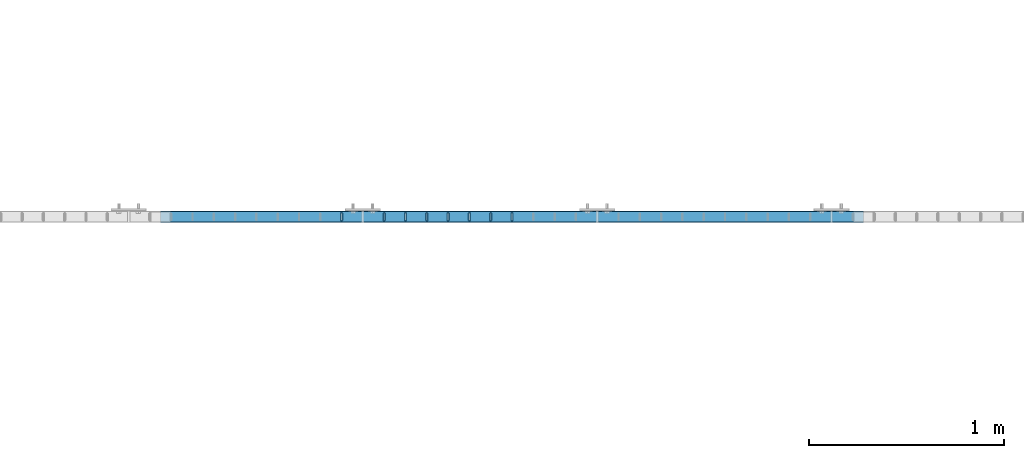
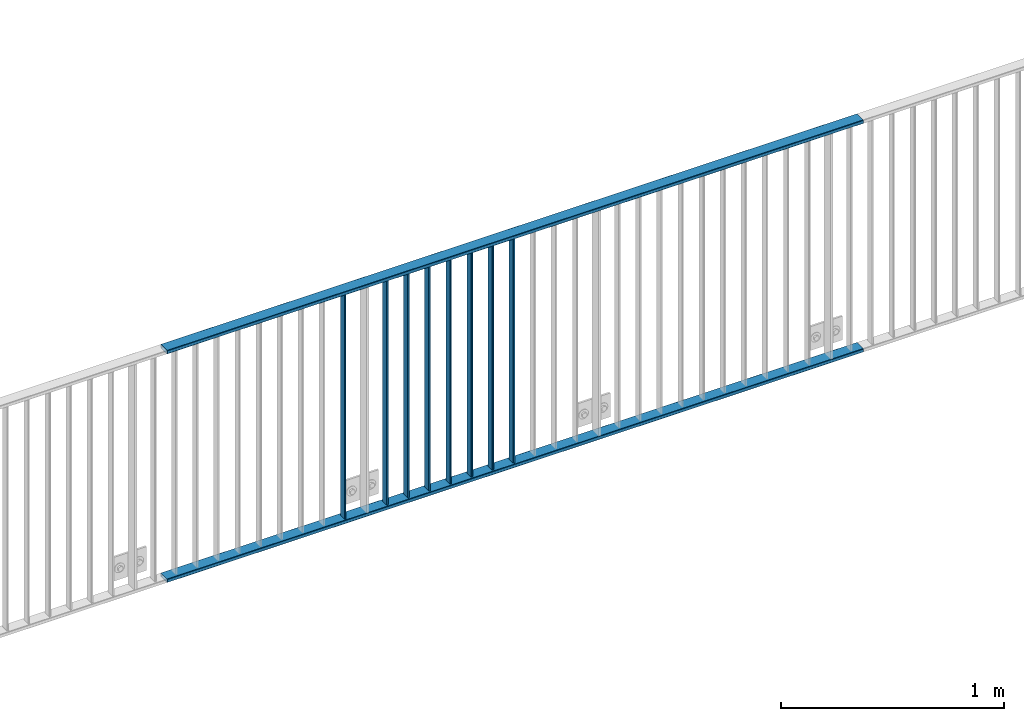
# One storey, part 4 of 156: 10 beams, 1 element without a shape of its own.
"""IFC2X3 building model written with IfcOpenShell, lengths in millimetres."""

from ifc_helpers import new_model, si_unit, frame, origin_with_axes, origin_2d_with_axis, place, context, subcontext, project, spatial, hollow_rectangle, extrude, clip, halfspace, material, type_object, element, aggregate, save


model = new_model("IFC2X3")

# Units and contexts
model_context = context("Model", 3, precision=1e-05, world=origin_with_axes())
body_context = subcontext(model_context, "Body", "Model", "MODEL_VIEW")
ifc_project = project(units=[si_unit("LENGTHUNIT", "METRE", prefix="MILLI"), si_unit("AREAUNIT", "SQUARE_METRE"), si_unit("VOLUMEUNIT", "CUBIC_METRE"), si_unit("MASSUNIT", "GRAM", prefix="KILO"), si_unit("TIMEUNIT", "SECOND"), si_unit("PLANEANGLEUNIT", "RADIAN"), si_unit("SOLIDANGLEUNIT", "STERADIAN"), si_unit("THERMODYNAMICTEMPERATUREUNIT", "DEGREE_CELSIUS"), si_unit("LUMINOUSINTENSITYUNIT", "LUMEN")], contexts=[model_context])

# Site, building, storey
site_placement = place(None, origin_with_axes())
site = spatial("IfcSite", under=ifc_project, at=site_placement, CompositionType="ELEMENT")
building_placement = place(site_placement, origin_with_axes())
building = spatial("IfcBuilding", under=site, at=building_placement, Name="Undefined", CompositionType="ELEMENT")
storey_placement = place(building_placement, origin_with_axes())
storey = spatial("IfcBuildingStorey", under=building, at=storey_placement, Name="Undefined", CompositionType="ELEMENT", Elevation=0.0)

# Assembly, beams
assembly_placement = place(storey_placement, origin_with_axes())
assembly = element("IfcElementAssembly", 1, at=assembly_placement, inside=storey, AssemblyPlace="NOTDEFINED", PredefinedType="RIGID_FRAME")
ifc_material = material(Name="STEEL/S235JR")
beam_type_1 = type_object("IfcBeamType", Name="K60/20/2", PredefinedType="NOTDEFINED")
beam_1_placement = place(assembly_placement, frame((14363.649999999, 10879.9998016357, 2740.0), z_axis=(0.0, 1.0, 0.0), x_axis=(1.0, 0.0, 0.0)))
beam_1 = element("IfcBeam", 2, at=beam_1_placement, type_object=beam_type_1, material=ifc_material, ObjectType="K60/20/2", context=body_context, shape_type="SweptSolid", body=[
    extrude(hollow_rectangle(XDim=20.0, YDim=60.0, WallThickness=2.0, InnerFilletRadius=2.0, OuterFilletRadius=4.0, at=origin_2d_with_axis()), frame((3600.0, 0.0, 0.0), z_axis=(-1.0, 0.0, 0.0), x_axis=(0.0, -1.0, 0.0)), (0.0, 0.0, 1.0), 3600.0),
])
beam_2_placement = place(assembly_placement, frame((14363.6457423371, 10879.9998016357, 3990.0), z_axis=(0.0, 1.0, 0.0), x_axis=(1.0, 0.0, 0.0)))
beam_2 = element("IfcBeam", 3, at=beam_2_placement, type_object=beam_type_1, material=ifc_material, ObjectType="K60/20/2", context=body_context, shape_type="SweptSolid", body=[
    extrude(hollow_rectangle(XDim=20.0, YDim=60.0, WallThickness=2.0, InnerFilletRadius=2.0, OuterFilletRadius=4.0, at=origin_2d_with_axis()), frame((3600.0, 0.0, 0.0), z_axis=(-1.0, 0.0, 0.0), x_axis=(0.0, -1.0, 0.0)), (0.0, 0.0, 1.0), 3600.0),
])
beam_type_2 = type_object("IfcBeamType", Name="K40/10/1.5", PredefinedType="NOTDEFINED")
beam_3_placement = place(assembly_placement, frame((16163.629999999, 10879.9998088346, 3980.00000000003), z_axis=(0.0, 1.0, 0.0), x_axis=(0.0, 0.0, -1.0)))
beam_3 = element("IfcBeam", 4, at=beam_3_placement, type_object=beam_type_2, material=ifc_material, ObjectType="K40/10/1.5", context=body_context, shape_type="Clipping", body=[
    clip(clip(extrude(hollow_rectangle(XDim=10.0, YDim=40.0, WallThickness=1.5, InnerFilletRadius=1.5, OuterFilletRadius=3.0, at=origin_2d_with_axis()), frame((1237.00000000003, 0.0, 0.0), z_axis=(-1.0, 0.0, 0.0), x_axis=(0.0, -1.0, 0.0)), (0.0, 0.0, 1.0), 1244.0), halfspace(frame((1237.00000000003, 3.90376720472705, 47.0154897941684), z_axis=(1.0, 0.0, 0.0), x_axis=(0.0, -0.761952806119621, -0.647632551101653)), False)), halfspace(frame((-6.99999999997453, -3.24498419219526, 46.4665039507308), z_axis=(-1.0, 0.0, 0.0), x_axis=(0.0, 0.75441426312288, -0.656398598106944)), False)),
])
beam_4_placement = place(assembly_placement, frame((16054.539999999, 10879.9998088346, 3980.00000000003), z_axis=(0.0, 1.0, 0.0), x_axis=(0.0, 0.0, -1.0)))
beam_4 = element("IfcBeam", 5, at=beam_4_placement, type_object=beam_type_2, material=ifc_material, ObjectType="K40/10/1.5", context=body_context, shape_type="Clipping", body=[
    clip(clip(extrude(hollow_rectangle(XDim=10.0, YDim=40.0, WallThickness=1.5, InnerFilletRadius=1.5, OuterFilletRadius=3.0, at=origin_2d_with_axis()), frame((1237.00000000003, 0.0, 0.0), z_axis=(-1.0, 0.0, 0.0), x_axis=(0.0, -1.0, 0.0)), (0.0, 0.0, 1.0), 1244.0), halfspace(frame((1237.00000000003, 3.90376720472705, 47.0154897941684), z_axis=(1.0, 0.0, 0.0), x_axis=(0.0, -0.761952806119621, -0.647632551101653)), False)), halfspace(frame((-6.99999999997453, -3.24498419219526, 46.4665039507308), z_axis=(-1.0, 0.0, 0.0), x_axis=(0.0, 0.75441426312288, -0.656398598106944)), False)),
])
beam_5_placement = place(assembly_placement, frame((15945.449999999, 10879.9998088346, 3980.00000000003), z_axis=(0.0, 1.0, 0.0), x_axis=(0.0, 0.0, -1.0)))
beam_5 = element("IfcBeam", 6, at=beam_5_placement, type_object=beam_type_2, material=ifc_material, ObjectType="K40/10/1.5", context=body_context, shape_type="Clipping", body=[
    clip(clip(extrude(hollow_rectangle(XDim=10.0, YDim=40.0, WallThickness=1.5, InnerFilletRadius=1.5, OuterFilletRadius=3.0, at=origin_2d_with_axis()), frame((1237.00000000003, 0.0, 0.0), z_axis=(-1.0, 0.0, 0.0), x_axis=(0.0, -1.0, 0.0)), (0.0, 0.0, 1.0), 1244.0), halfspace(frame((1237.00000000003, 3.90376720472705, 47.0154897941684), z_axis=(1.0, 0.0, 0.0), x_axis=(0.0, -0.761952806119621, -0.647632551101653)), False)), halfspace(frame((-6.99999999997453, -3.24498419219526, 46.4665039507308), z_axis=(-1.0, 0.0, 0.0), x_axis=(0.0, 0.75441426312288, -0.656398598106944)), False)),
])
beam_6_placement = place(assembly_placement, frame((15836.359999999, 10879.9998088346, 3980.00000000003), z_axis=(0.0, 1.0, 0.0), x_axis=(0.0, 0.0, -1.0)))
beam_6 = element("IfcBeam", 7, at=beam_6_placement, type_object=beam_type_2, material=ifc_material, ObjectType="K40/10/1.5", context=body_context, shape_type="Clipping", body=[
    clip(clip(extrude(hollow_rectangle(XDim=10.0, YDim=40.0, WallThickness=1.5, InnerFilletRadius=1.5, OuterFilletRadius=3.0, at=origin_2d_with_axis()), frame((1237.00000000003, 0.0, 0.0), z_axis=(-1.0, 0.0, 0.0), x_axis=(0.0, -1.0, 0.0)), (0.0, 0.0, 1.0), 1244.0), halfspace(frame((1237.00000000003, 3.90376720472705, 47.0154897941684), z_axis=(1.0, 0.0, 0.0), x_axis=(0.0, -0.761952806119621, -0.647632551101653)), False)), halfspace(frame((-6.99999999997453, -3.24498419219526, 46.4665039507308), z_axis=(-1.0, 0.0, 0.0), x_axis=(0.0, 0.75441426312288, -0.656398598106944)), False)),
])
beam_7_placement = place(assembly_placement, frame((15727.269999999, 10879.9998088346, 3980.00000000003), z_axis=(0.0, 1.0, 0.0), x_axis=(0.0, 0.0, -1.0)))
beam_7 = element("IfcBeam", 8, at=beam_7_placement, type_object=beam_type_2, material=ifc_material, ObjectType="K40/10/1.5", context=body_context, shape_type="Clipping", body=[
    clip(clip(extrude(hollow_rectangle(XDim=10.0, YDim=40.0, WallThickness=1.5, InnerFilletRadius=1.5, OuterFilletRadius=3.0, at=origin_2d_with_axis()), frame((1237.00000000003, 0.0, 0.0), z_axis=(-1.0, 0.0, 0.0), x_axis=(0.0, -1.0, 0.0)), (0.0, 0.0, 1.0), 1244.0), halfspace(frame((1237.00000000003, 3.90376720472705, 47.0154897941684), z_axis=(1.0, 0.0, 0.0), x_axis=(0.0, -0.761952806119621, -0.647632551101653)), False)), halfspace(frame((-6.99999999997453, -3.24498419219526, 46.4665039507308), z_axis=(-1.0, 0.0, 0.0), x_axis=(0.0, 0.75441426312288, -0.656398598106944)), False)),
])
beam_8_placement = place(assembly_placement, frame((15618.179999999, 10879.9998088346, 3980.00000000003), z_axis=(0.0, 1.0, 0.0), x_axis=(0.0, 0.0, -1.0)))
beam_8 = element("IfcBeam", 9, at=beam_8_placement, type_object=beam_type_2, material=ifc_material, ObjectType="K40/10/1.5", context=body_context, shape_type="Clipping", body=[
    clip(clip(extrude(hollow_rectangle(XDim=10.0, YDim=40.0, WallThickness=1.5, InnerFilletRadius=1.5, OuterFilletRadius=3.0, at=origin_2d_with_axis()), frame((1237.00000000003, 0.0, 0.0), z_axis=(-1.0, 0.0, 0.0), x_axis=(0.0, -1.0, 0.0)), (0.0, 0.0, 1.0), 1244.0), halfspace(frame((1237.00000000003, 3.90376720472705, 47.0154897941684), z_axis=(1.0, 0.0, 0.0), x_axis=(0.0, -0.761952806119621, -0.647632551101653)), False)), halfspace(frame((-6.99999999997453, -3.24498419219526, 46.4665039507308), z_axis=(-1.0, 0.0, 0.0), x_axis=(0.0, 0.75441426312288, -0.656398598106944)), False)),
])
beam_9_placement = place(assembly_placement, frame((15509.089999999, 10879.9998088346, 3980.00000000003), z_axis=(0.0, 1.0, 0.0), x_axis=(0.0, 0.0, -1.0)))
beam_9 = element("IfcBeam", 10, at=beam_9_placement, type_object=beam_type_2, material=ifc_material, ObjectType="K40/10/1.5", context=body_context, shape_type="Clipping", body=[
    clip(clip(extrude(hollow_rectangle(XDim=10.0, YDim=40.0, WallThickness=1.5, InnerFilletRadius=1.5, OuterFilletRadius=3.0, at=origin_2d_with_axis()), frame((1237.00000000003, 0.0, 0.0), z_axis=(-1.0, 0.0, 0.0), x_axis=(0.0, -1.0, 0.0)), (0.0, 0.0, 1.0), 1244.0), halfspace(frame((1237.00000000003, 3.63803898150218, 46.7940496082883), z_axis=(1.0, 0.0, 0.0), x_axis=(0.0, -0.758923924280425, -0.65117929724063)), False)), halfspace(frame((-6.99999999997453, -2.66359292875859, 45.9820112315028), z_axis=(-1.0, 0.0, 0.0), x_axis=(0.0, 0.747680594279002, -0.664058528247773)), False)),
])
beam_10_placement = place(assembly_placement, frame((15290.899999999, 10879.9998088346, 3980.00000000003), z_axis=(0.0, 1.0, 0.0), x_axis=(0.0, 0.0, -1.0)))
beam_10 = element("IfcBeam", 11, at=beam_10_placement, type_object=beam_type_2, material=ifc_material, ObjectType="K40/10/1.5", context=body_context, shape_type="Clipping", body=[
    clip(clip(extrude(hollow_rectangle(XDim=10.0, YDim=40.0, WallThickness=1.5, InnerFilletRadius=1.5, OuterFilletRadius=3.0, at=origin_2d_with_axis()), frame((1237.00000000003, 0.0, 0.0), z_axis=(-1.0, 0.0, 0.0), x_axis=(0.0, -1.0, 0.0)), (0.0, 0.0, 1.0), 1244.0), halfspace(frame((1237.00000000003, 3.90376720472705, 47.0154897941684), z_axis=(1.0, 0.0, 0.0), x_axis=(0.0, -0.761952806119621, -0.647632551101653)), False)), halfspace(frame((-6.99999999997453, -3.24498419219526, 46.4665039507308), z_axis=(-1.0, 0.0, 0.0), x_axis=(0.0, 0.75441426312288, -0.656398598106944)), False)),
])
aggregate(assembly, [beam_1, beam_2, beam_3, beam_4, beam_5, beam_6, beam_7, beam_8, beam_9, beam_10])

save(model, "model.ifc")
